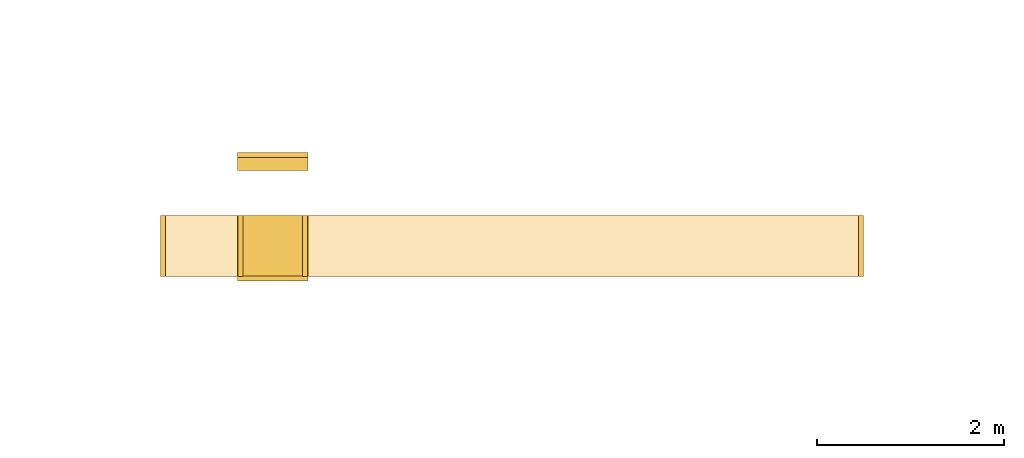
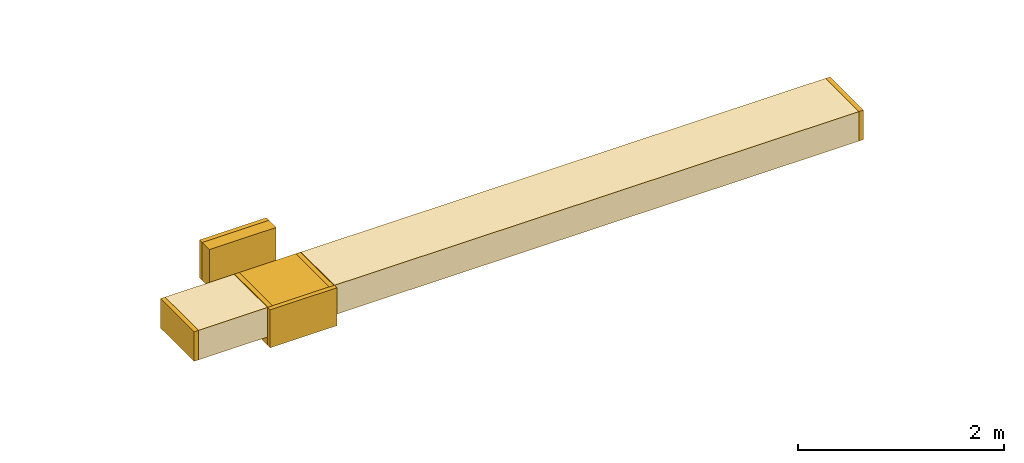
# One storey, part 1 of 9: 10 coverings.
"""IFC2X3 building model written with IfcOpenShell, lengths in millimetres."""

from ifc_helpers import new_model, entity, si_unit, converted_unit, derived_unit, direction, frame, frame_2d, origin, origin_2d_with_axis, place, context, subcontext, project, spatial, rectangle, extrude, element, save


model = new_model("IFC2X3")

# Units and contexts
model_context = context("Model", 3, precision=0.01, world=origin(), true_north=direction((6.12303176911189e-17, 1.0)))
body_context = subcontext(model_context, "Body", "Model", "MODEL_VIEW")
ifc_project = project(units=[si_unit("LENGTHUNIT", "METRE", prefix="MILLI"), si_unit("AREAUNIT", "SQUARE_METRE"), si_unit("VOLUMEUNIT", "CUBIC_METRE"), converted_unit("PLANEANGLEUNIT", "DEGREE", entity("IfcRatioMeasure", 0.0174532925199433), si_unit("PLANEANGLEUNIT", "RADIAN"), dimensions=[0, 0, 0, 0, 0, 0, 0]), si_unit("MASSUNIT", "GRAM", prefix="KILO"), derived_unit("MASSDENSITYUNIT", [(si_unit("MASSUNIT", "GRAM", prefix="KILO"), 1), (si_unit("LENGTHUNIT", "METRE"), -3)]), derived_unit("MOMENTOFINERTIAUNIT", [(si_unit("LENGTHUNIT", "METRE"), 4)]), si_unit("TIMEUNIT", "SECOND"), si_unit("FREQUENCYUNIT", "HERTZ"), si_unit("THERMODYNAMICTEMPERATUREUNIT", "DEGREE_CELSIUS"), derived_unit("THERMALTRANSMITTANCEUNIT", [(si_unit("MASSUNIT", "GRAM", prefix="KILO"), 1), (si_unit("THERMODYNAMICTEMPERATUREUNIT", "KELVIN"), -1), (si_unit("TIMEUNIT", "SECOND"), -3)]), derived_unit("VOLUMETRICFLOWRATEUNIT", [(si_unit("LENGTHUNIT", "METRE"), 3), (si_unit("TIMEUNIT", "SECOND"), -1)]), derived_unit("MASSFLOWRATEUNIT", [(si_unit("MASSUNIT", "GRAM", prefix="KILO"), 1), (si_unit("TIMEUNIT", "SECOND"), -1)]), derived_unit("ROTATIONALFREQUENCYUNIT", [(si_unit("TIMEUNIT", "SECOND"), -1)]), si_unit("ELECTRICCURRENTUNIT", "AMPERE"), si_unit("ELECTRICVOLTAGEUNIT", "VOLT"), si_unit("POWERUNIT", "WATT"), si_unit("FORCEUNIT", "NEWTON", prefix="KILO"), si_unit("ILLUMINANCEUNIT", "LUX"), si_unit("LUMINOUSFLUXUNIT", "LUMEN"), si_unit("LUMINOUSINTENSITYUNIT", "CANDELA"), derived_unit("USERDEFINED", [(si_unit("MASSUNIT", "GRAM", prefix="KILO"), -1), (si_unit("LENGTHUNIT", "METRE"), -2), (si_unit("TIMEUNIT", "SECOND"), 3), (si_unit("LUMINOUSFLUXUNIT", "LUMEN"), 1)]), derived_unit("LINEARVELOCITYUNIT", [(si_unit("LENGTHUNIT", "METRE"), 1), (si_unit("TIMEUNIT", "SECOND"), -1)]), si_unit("PRESSUREUNIT", "PASCAL"), derived_unit("USERDEFINED", [(si_unit("LENGTHUNIT", "METRE"), -2), (si_unit("MASSUNIT", "GRAM", prefix="KILO"), 1), (si_unit("TIMEUNIT", "SECOND"), -2)]), derived_unit("LINEARFORCEUNIT", [(si_unit("MASSUNIT", "GRAM", prefix="KILO"), 1), (si_unit("LENGTHUNIT", "METRE"), 1), (si_unit("TIMEUNIT", "SECOND"), -2), (si_unit("LENGTHUNIT", "METRE"), -1)]), derived_unit("PLANARFORCEUNIT", [(si_unit("MASSUNIT", "GRAM", prefix="KILO"), 1), (si_unit("LENGTHUNIT", "METRE"), 1), (si_unit("TIMEUNIT", "SECOND"), -2), (si_unit("LENGTHUNIT", "METRE"), -2)])], contexts=[model_context])

# Site, building, storey
site_placement = place(None, frame((0.0, -0.00077364408347762, 0.0)))
site = spatial("IfcSite", under=ifc_project, at=site_placement, CompositionType="ELEMENT")
building_placement = place(site_placement, origin())
building = spatial("IfcBuilding", under=site, at=building_placement, CompositionType="ELEMENT")
storey_placement = place(building_placement, frame((0.0, 0.0, 24000.0)))
storey = spatial("IfcBuildingStorey", under=building, at=storey_placement, CompositionType="ELEMENT", Elevation=24000.0)

# Coverings
covering_1_placement = place(storey_placement, frame((41005.983899498, 9294.5812458059, 2575.0)))
element("IfcCovering", 1, at=covering_1_placement, inside=storey, PredefinedType="INSULATION", context=body_context, shape_type="SweptSolid", body=[
    extrude(rectangle(XDim=49.9999999999973, YDim=650.0, at=frame_2d((4.33253433129721e-12, 0.0), x_axis=(1.0, 0.0))), frame((25.0, 325.0, 0.0)), (0.0, 0.0, 1.0), 349.999999999998),
])
covering_2_placement = place(storey_placement, frame((41055.983899498, 9294.58124580589, 2575.0)))
element("IfcCovering", 2, at=covering_2_placement, inside=storey, PredefinedType="INSULATION", context=body_context, shape_type="SweptSolid", body=[
    extrude(rectangle(XDim=778.881621530124, YDim=650.000000000001, at=frame_2d((0.0, 5.40012479177676e-13), x_axis=(1.0, 0.0))), frame((389.440810765062, 325.0, 0.0)), (0.0, 0.0, 1.0), 349.999999999998),
])
covering_3_placement = place(storey_placement, frame((42574.8655210282, 9294.58124580587, 2575.0)))
element("IfcCovering", 3, at=covering_3_placement, inside=storey, PredefinedType="INSULATION", context=body_context, shape_type="SweptSolid", body=[
    extrude(rectangle(XDim=5885.0094274255, YDim=650.000000000001, at=frame_2d((-4.32009983342141e-12, 5.40012479177676e-13), x_axis=(1.0, 0.0))), frame((2942.50471371275, 325.0, 0.0), z_axis=(0.0, 0.0, 1.0), x_axis=(-1.0, 0.0, 0.0)), (0.0, 0.0, 1.0), 349.999999999998),
])
covering_4_placement = place(storey_placement, frame((48459.8749484537, 9294.58124580587, 2575.0)))
element("IfcCovering", 4, at=covering_4_placement, inside=storey, PredefinedType="INSULATION", context=body_context, shape_type="SweptSolid", body=[
    extrude(rectangle(XDim=49.9999999999973, YDim=650.000000000001, at=frame_2d((4.33253433129721e-12, 5.40012479177676e-13), x_axis=(1.0, 0.0))), frame((25.0, 325.0, 0.0), z_axis=(0.0, 0.0, 1.0), x_axis=(-1.0, 0.0, 0.0)), (0.0, 0.0, 1.0), 349.999999999998),
])
covering_5_placement = place(storey_placement, frame((41829.8655210282, 10425.5009107234, 2475.0)))
element("IfcCovering", 5, at=covering_5_placement, inside=storey, PredefinedType="INSULATION", context=body_context, shape_type="SweptSolid", body=[
    extrude(rectangle(XDim=139.488841597194, YDim=750.000000000003, at=origin_2d_with_axis()), frame((375.0, 69.7444207985969, 0.0), z_axis=(0.0, 0.0, 1.0), x_axis=(0.0, 1.0, 0.0)), (0.0, 0.0, 1.0), 450.000000000002),
])
covering_6_placement = place(storey_placement, frame((41829.8655210282, 9247.20401040959, 2475.0)))
element("IfcCovering", 6, at=covering_6_placement, inside=storey, PredefinedType="INSULATION", context=body_context, shape_type="SweptSolid", body=[
    extrude(rectangle(XDim=50.0000000000016, YDim=750.000000000003, at=origin_2d_with_axis()), frame((375.0, 25.0, 0.0), z_axis=(0.0, 0.0, 1.0), x_axis=(0.0, 1.0, 0.0)), (0.0, 0.0, 1.0), 450.000000000002),
])
covering_7_placement = place(storey_placement, frame((41829.8655210282, 10564.9897523206, 2475.0)))
element("IfcCovering", 7, at=covering_7_placement, inside=storey, PredefinedType="INSULATION", context=body_context, shape_type="SweptSolid", body=[
    extrude(rectangle(XDim=750.000000000003, YDim=51.0960000000016, at=origin_2d_with_axis()), frame((375.0, 25.5480000000008, 0.0)), (0.0, 0.0, 1.0), 450.000000000002),
])
covering_8_placement = place(storey_placement, frame((41829.8655210282, 9297.20401040959, 2475.0)))
element("IfcCovering", 8, at=covering_8_placement, inside=storey, PredefinedType="INSULATION", context=body_context, shape_type="SweptSolid", body=[
    extrude(rectangle(XDim=648.296900313849, YDim=750.000000000003, at=frame_2d((-5.40012479177676e-13, -4.32009983342141e-12), x_axis=(1.0, 0.0))), frame((375.0, 324.148450156929, 0.0), z_axis=(0.0, 0.0, 1.0), x_axis=(0.0, 1.0, 0.0)), (0.0, 0.0, 1.0), 450.000000000002),
])
covering_9_placement = place(storey_placement, frame((42523.7695210281, 9294.58124580589, 2575.0)))
element("IfcCovering", 9, at=covering_9_placement, inside=storey, PredefinedType="INSULATION", context=body_context, shape_type="SweptSolid", body=[
    extrude(rectangle(XDim=51.0960000000449, YDim=650.000000000001, at=frame_2d((8.66151594891562e-12, 5.40012479177676e-13), x_axis=(1.0, 0.0))), frame((25.5480000000354, 325.0, 0.0), z_axis=(0.0, 0.0, 1.0), x_axis=(-1.0, 0.0, 0.0)), (0.0, 0.0, 1.0), 349.999999999998),
])
covering_10_placement = place(storey_placement, frame((41834.8655210281, 9294.58124580589, 2575.0)))
element("IfcCovering", 10, at=covering_10_placement, inside=storey, PredefinedType="INSULATION", context=body_context, shape_type="SweptSolid", body=[
    extrude(rectangle(XDim=650.000000000001, YDim=51.0960000000275, at=frame_2d((0.0, 4.33253433129721e-12), x_axis=(1.0, 0.0))), frame((25.5480000000181, 325.0, 0.0), z_axis=(0.0, 0.0, 1.0), x_axis=(0.0, -1.0, 0.0)), (0.0, 0.0, 1.0), 349.999999999998),
])

save(model, "model.ifc")
